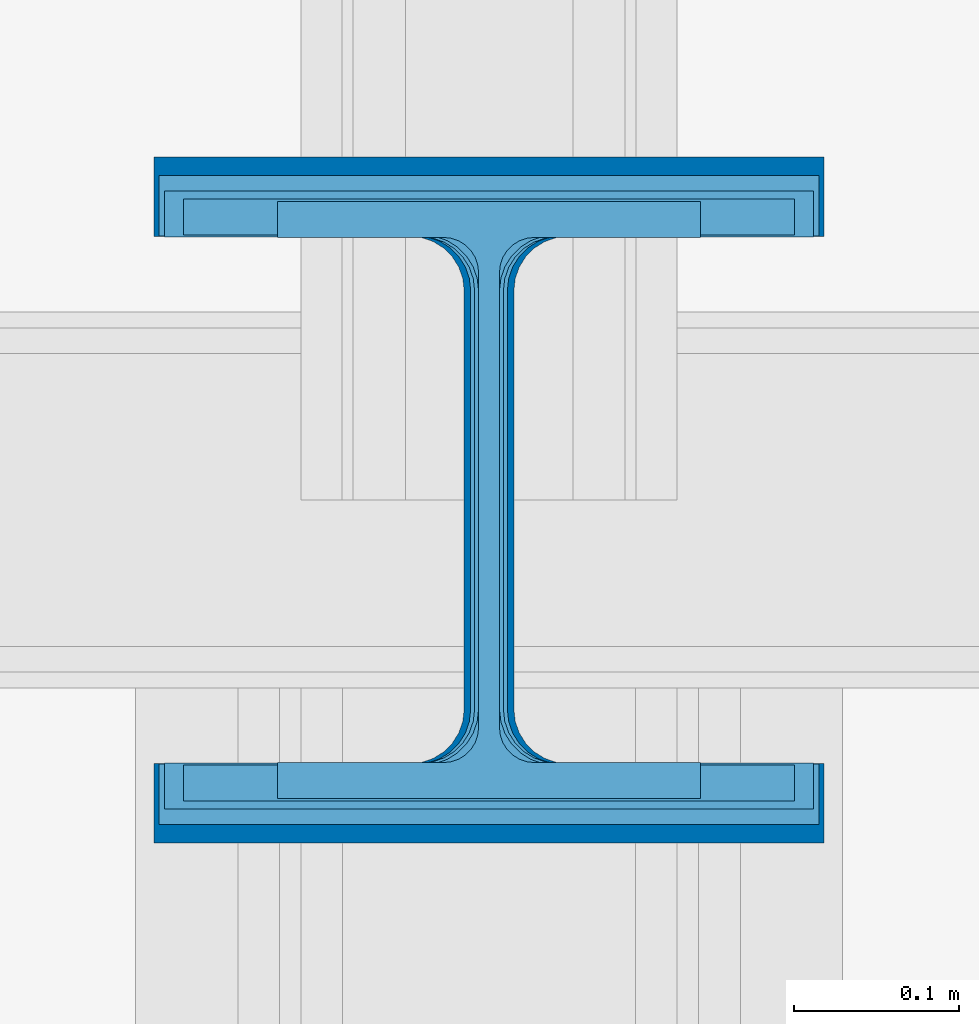
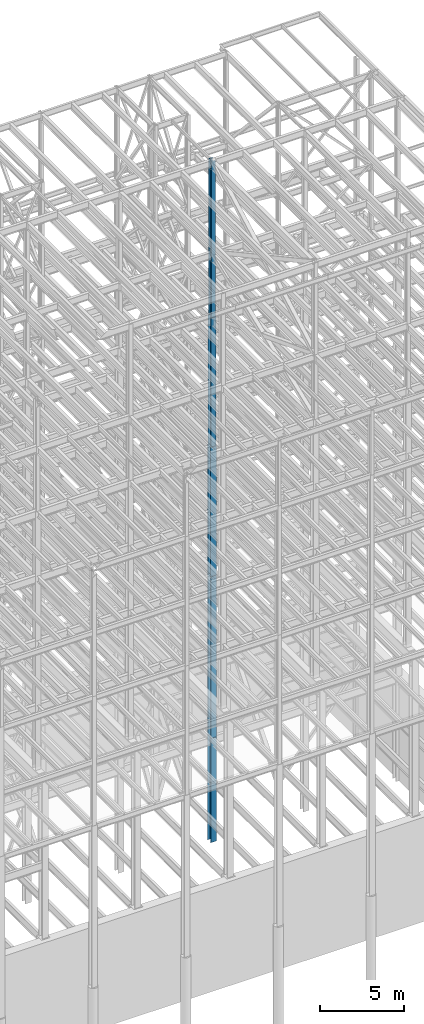
# One storey, part 91 of 150: 5 columns.
"""IFC2X3 building model written with IfcOpenShell, lengths in millimetres."""

from ifc_helpers import new_model, si_unit, frame, origin_with_axes, origin_2d_with_axis, place, context, subcontext, project, spatial, i_section, extrude, material, type_object, element, save


model = new_model("IFC2X3")

# Units and contexts
model_context = context("Model", 3, precision=1e-05, world=origin_with_axes())
body_context = subcontext(model_context, "Body", "Model", "MODEL_VIEW")
ifc_project = project(units=[si_unit("LENGTHUNIT", "METRE", prefix="MILLI"), si_unit("AREAUNIT", "SQUARE_METRE"), si_unit("VOLUMEUNIT", "CUBIC_METRE"), si_unit("MASSUNIT", "GRAM", prefix="KILO"), si_unit("TIMEUNIT", "SECOND"), si_unit("PLANEANGLEUNIT", "RADIAN"), si_unit("SOLIDANGLEUNIT", "STERADIAN"), si_unit("THERMODYNAMICTEMPERATUREUNIT", "DEGREE_CELSIUS"), si_unit("LUMINOUSINTENSITYUNIT", "LUMEN")], contexts=[model_context])

# Site, building, storey
site_placement = place(None, origin_with_axes())
site = spatial("IfcSite", under=ifc_project, at=site_placement, CompositionType="ELEMENT")
building_placement = place(site_placement, origin_with_axes())
building = spatial("IfcBuilding", under=site, at=building_placement, Name="Undefined", CompositionType="ELEMENT")
storey_placement = place(building_placement, origin_with_axes())
storey = spatial("IfcBuildingStorey", under=building, at=storey_placement, Name="Undefined", CompositionType="ELEMENT", Elevation=0.0)

# Columns
ifc_material = material(Name="STEEL/A992")
column_type_1 = type_object("IfcColumnType", Name="W14X193", PredefinedType="NOTDEFINED")
column_1_placement = place(storey_placement, frame((75793.6, 22479.0, 23774.40188976), z_axis=(0.0, 0.0, 1.0), x_axis=(1.0, 0.0, 0.0)))
element("IfcColumn", 1, at=column_1_placement, inside=storey, type_object=column_type_1, material=ifc_material, Name="COLUMN", ObjectType="W14X193", context=body_context, shape_type="SweptSolid", body=[
    extrude(i_section(OverallWidth=400.05, OverallDepth=393.7, WebThickness=22.225, FlangeThickness=36.576, FilletRadius=33.2739, at=origin_2d_with_axis()), frame((0.0, 0.0, 11811.0), z_axis=(0.0, 0.0, -1.0), x_axis=(-1.0, 0.0, 0.0)), (0.0, 0.0, 1.0), 11811.0),
])
column_type_2 = type_object("IfcColumnType", Name="W14X257", PredefinedType="NOTDEFINED")
column_2_placement = place(storey_placement, frame((75793.6, 22479.0, 16154.40188976), z_axis=(0.0, 0.0, 1.0), x_axis=(1.0, 0.0, 0.0)))
element("IfcColumn", 2, at=column_2_placement, inside=storey, type_object=column_type_2, material=ifc_material, Name="COLUMN", ObjectType="W14X257", context=body_context, shape_type="SweptSolid", body=[
    extrude(i_section(OverallWidth=406.4, OverallDepth=415.925, WebThickness=30.1625, FlangeThickness=48.006, FilletRadius=32.9564, at=origin_2d_with_axis()), frame((0.0, 0.0, 7620.0), z_axis=(0.0, 0.0, -1.0), x_axis=(-1.0, 0.0, 0.0)), (0.0, 0.0, 1.0), 7620.0),
])
column_type_3 = type_object("IfcColumnType", Name="W14X145", PredefinedType="NOTDEFINED")
column_3_placement = place(storey_placement, frame((75793.6, 22479.0, 35585.40188976), z_axis=(0.0, 0.0, 1.0), x_axis=(1.0, 0.0, 0.0)))
element("IfcColumn", 3, at=column_3_placement, inside=storey, type_object=column_type_3, material=ifc_material, Name="COLUMN", ObjectType="W14X145", context=body_context, shape_type="SweptSolid", body=[
    extrude(i_section(OverallWidth=393.7, OverallDepth=374.65, WebThickness=17.4625, FlangeThickness=27.686, FilletRadius=32.6389, at=origin_2d_with_axis()), frame((0.0, 0.0, 9448.8), z_axis=(0.0, 0.0, -1.0), x_axis=(-1.0, 0.0, 0.0)), (0.0, 0.0, 1.0), 9448.79999999999),
])
column_type_4 = type_object("IfcColumnType", Name="W14X109", PredefinedType="NOTDEFINED")
column_4_placement = place(storey_placement, frame((75793.6, 22479.0, 45034.20188976), z_axis=(0.0, 0.0, 1.0), x_axis=(1.0, 0.0, 0.0)))
element("IfcColumn", 4, at=column_4_placement, inside=storey, type_object=column_type_4, material=ifc_material, Name="COLUMN", ObjectType="W14X109", context=body_context, shape_type="SweptSolid", body=[
    extrude(i_section(OverallWidth=370.84, OverallDepth=365.125, WebThickness=12.6999, FlangeThickness=21.844, FilletRadius=33.7184, at=origin_2d_with_axis()), frame((0.0, 0.0, 9448.8), z_axis=(0.0, 0.0, -1.0), x_axis=(-1.0, 0.0, 0.0)), (0.0, 0.0, 1.0), 9448.8),
])
column_type_5 = type_object("IfcColumnType", Name="W14X82", PredefinedType="NOTDEFINED")
column_5_placement = place(storey_placement, frame((75793.6, 22479.0, 54483.00188976), z_axis=(0.0, 0.0, 1.0), x_axis=(1.0, 0.0, 0.0)))
element("IfcColumn", 5, at=column_5_placement, inside=storey, type_object=column_type_5, material=ifc_material, Name="COLUMN", ObjectType="W14X82", context=body_context, shape_type="SweptSolid", body=[
    extrude(i_section(OverallWidth=256.54, OverallDepth=361.95, WebThickness=12.6999, FlangeThickness=21.717, FilletRadius=21.1455, at=origin_2d_with_axis()), frame((0.0, 0.0, 11430.0), z_axis=(0.0, 0.0, -1.0), x_axis=(-1.0, 0.0, 0.0)), (0.0, 0.0, 1.0), 11430.0),
])

save(model, "model.ifc")
